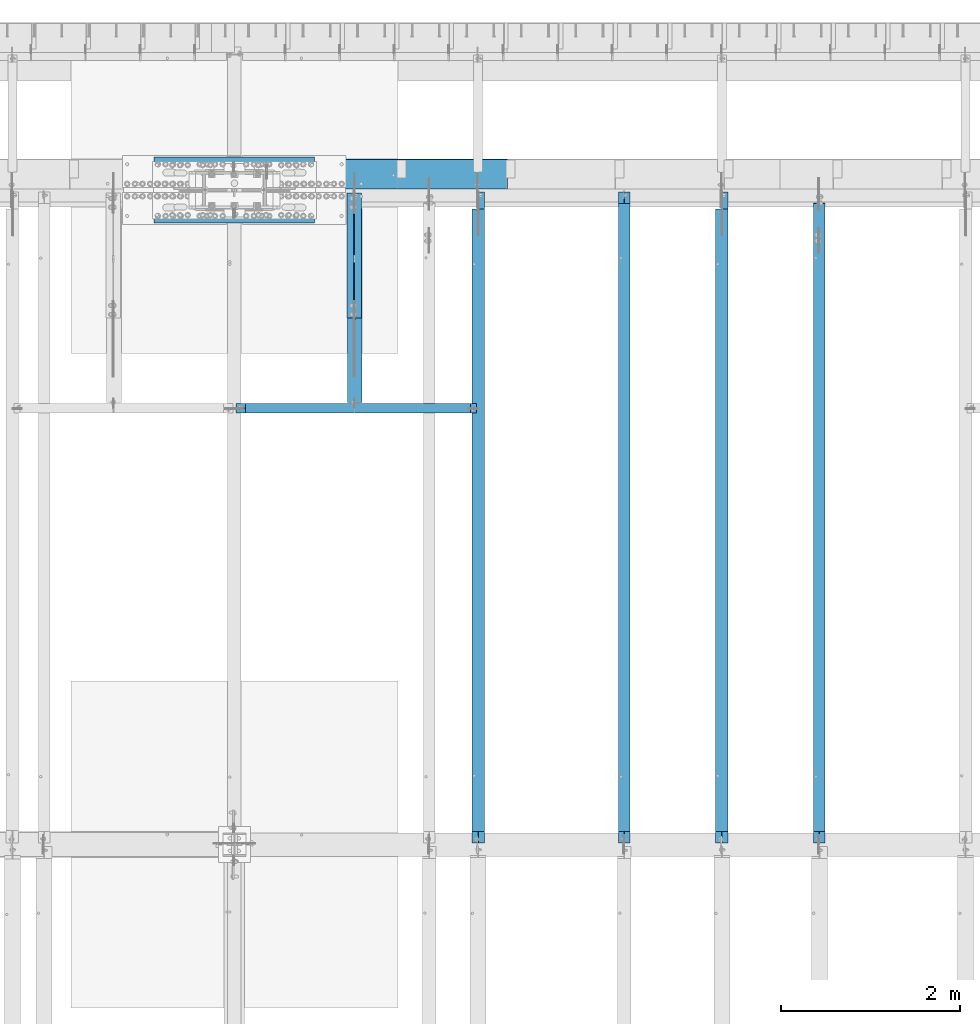
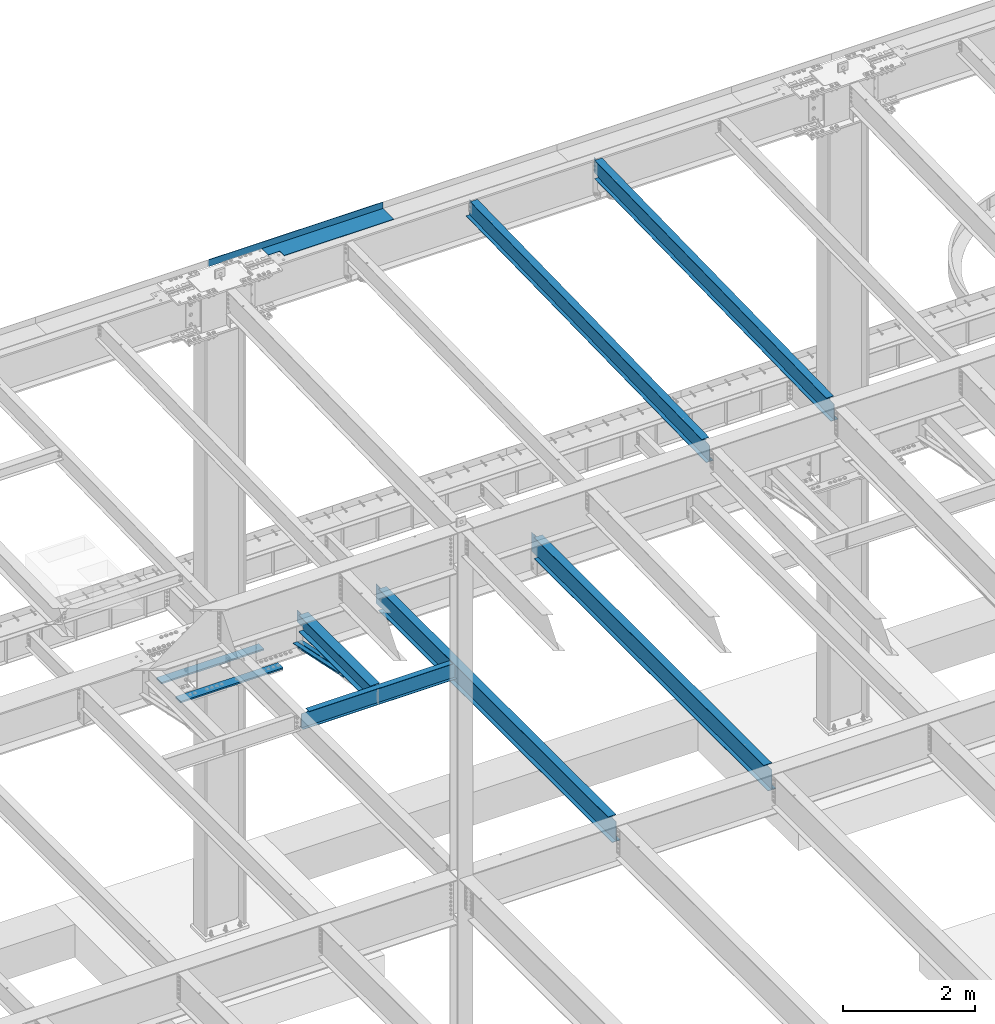
# One storey, part 1129 of 1763: 11 beams, 9 elements without a shape of their own.
"""IFC2X3 building model written with IfcOpenShell, lengths in millimetres."""

from ifc_helpers import new_model, si_unit, frame, origin_with_axes, place, context, subcontext, project, spatial, faceted_brep, material, type_object, element, aggregate, save


model = new_model("IFC2X3")

# Units and contexts
model_context = context("Model", 3, precision=1e-05, world=origin_with_axes())
body_context = subcontext(model_context, "Body", "Model", "MODEL_VIEW")
ifc_project = project(units=[si_unit("LENGTHUNIT", "METRE", prefix="MILLI"), si_unit("AREAUNIT", "SQUARE_METRE"), si_unit("VOLUMEUNIT", "CUBIC_METRE"), si_unit("MASSUNIT", "GRAM", prefix="KILO"), si_unit("TIMEUNIT", "SECOND"), si_unit("PLANEANGLEUNIT", "RADIAN"), si_unit("SOLIDANGLEUNIT", "STERADIAN"), si_unit("THERMODYNAMICTEMPERATUREUNIT", "DEGREE_CELSIUS"), si_unit("LUMINOUSINTENSITYUNIT", "LUMEN")], contexts=[model_context])

# Site, building, storey
site_placement = place(None, origin_with_axes())
site = spatial("IfcSite", under=ifc_project, at=site_placement, CompositionType="ELEMENT")
building_placement = place(site_placement, origin_with_axes())
building = spatial("IfcBuilding", under=site, at=building_placement, Name="Undefined", CompositionType="ELEMENT")
storey_placement = place(building_placement, origin_with_axes())
storey = spatial("IfcBuildingStorey", under=building, at=storey_placement, Name="Undefined", CompositionType="ELEMENT", Elevation=0.0)

# Assembly, beam
assembly_1_placement = place(storey_placement, origin_with_axes())
assembly_1 = element("IfcElementAssembly", 1, at=assembly_1_placement, inside=storey, Name="BEAM", AssemblyPlace="NOTDEFINED", PredefinedType="RIGID_FRAME")
ifc_material_1 = material(Name="STEEL/A992")
beam_type_1 = type_object("IfcBeamType", Name="W16X26", PredefinedType="NOTDEFINED")
beam_1_placement = place(assembly_1_placement, frame((-67042.7372736984, 44805.6, 4994.275), z_axis=(0.0, 0.0, 1.0), x_axis=(0.0, 1.0, 0.0)))
beam_1 = element("IfcBeam", 2, at=beam_1_placement, type_object=beam_type_1, material=ifc_material_1, Name="BEAM", ObjectType="W16X26", context=body_context, shape_type="Brep", body=[
    faceted_brep([(7104.06248869727, 3.17500000000291, -190.5), (7104.06248869734, 3.17487653380522, -200.025), (7104.06247902929, 69.8499999999985, -200.025), (7104.06247902929, 69.8499999999985, -190.5), (7294.5625, 3.17500000000291, -190.5), (7294.5625, 3.17490415680368, -200.025), (146.04999924302, 3.17499999999927, 190.5), (146.04999924302, 69.8499999999985, 190.5), (7104.0625, 69.8499999999985, 190.5), (7104.0625, 3.17500000000291, 190.5), (146.04999943226, -69.8499999999985, 200.025), (146.04999943226, 69.8499999999985, 200.025), (146.04999943226, 3.17500000000291, 180.715001487731), (146.04999943226, -3.17500000000291, 180.715001487731), (146.04999924302, -3.17499999999927, 190.5), (146.04999924302, -69.8499999999985, 190.5), (145.083269509669, 3.17500000000291, 175.854921969685), (145.083269509669, -3.17500000000291, 175.854921969685), (142.330255609195, 3.17500000000291, 171.734745501532), (142.330255609195, -3.17500000000291, 171.734745501532), (138.210079141041, 3.17500000000291, 168.981731601053), (138.210079141041, -3.17500000000291, 168.981731601053), (133.349999622995, 3.17500000000291, 168.015001678466), (133.349999622995, -3.17500000000291, 168.015001678466), (19.0499999999956, 3.17500000000291, 168.015001678466), (19.0499999999956, -3.17500000000291, 168.015001678466), (19.0499999999956, 3.17499999999927, -190.5), (19.0499999999956, 69.8499999999985, -190.5), (19.0499999999956, 69.8499999999985, -200.025), (19.0499999999956, -69.8499999999985, -200.025), (19.0499999999956, -69.8499999999985, -190.5), (19.0499999999956, -3.17499999999927, -190.5), (7294.5625, -69.8499999999985, -200.025), (7294.5625, -69.8499999999985, -190.5), (7294.5625, -3.17500000000291, -190.5), (7111.90242029122, -3.17500000000291, 156.541729922587), (7107.78224382307, -3.17500000000291, 159.294743823066), (7105.02922992258, -3.17500000000291, 163.414920291219), (7104.0625, -3.17500000000291, 168.274999809265), (7104.0625, -3.17500000000291, 190.5), (7294.5625, -3.17500000000291, 155.575), (7116.76249980927, -3.17500000000291, 155.575), (7104.0625, -69.8499999999985, 190.5), (7104.0625, -69.8499999999985, 200.025), (7104.0625, 69.8499999999985, 200.025), (7104.0625, 3.17500000000291, 168.274999809265), (7105.02922992258, 3.17500000000291, 163.414920291219), (7107.78224382307, 3.17500000000291, 159.294743823066), (7111.90242029122, 3.17500000000291, 156.541729922587), (7116.76249980927, 3.17500000000291, 155.575), (7294.5625, 3.17500000000291, 155.575), (7294.5625, 3.17500000000291, -184.976846570121)], [[[0, 1, 2, 3]], [[4, 5, 1, 0]], [[6, 7, 8, 9]], [[10, 11, 7, 6, 12, 13, 14, 15]], [[13, 12, 16, 17]], [[17, 16, 18, 19]], [[19, 18, 20, 21]], [[21, 20, 22, 23]], [[23, 22, 24, 25]], [[26, 27, 28, 29, 30, 31, 25, 24]], [[30, 29, 32, 33]], [[31, 30, 33, 34]], [[35, 36, 37, 38, 39, 14, 13, 17, 19, 21, 23, 25, 31, 34, 40, 41]], [[15, 14, 39, 42]], [[10, 15, 42, 43]], [[11, 10, 43, 44]], [[7, 11, 44, 8]], [[43, 42, 39, 38, 45, 9, 8, 44]], [[37, 46, 45, 38]], [[36, 47, 46, 37]], [[35, 48, 47, 36]], [[41, 49, 48, 35]], [[40, 50, 49, 41]], [[51, 4, 0, 26, 24, 22, 20, 18, 16, 12, 6, 9, 45, 46, 47, 48, 49, 50]], [[27, 26, 0, 3]], [[28, 27, 3, 2]], [[32, 29, 28, 2, 1, 5]], [[51, 50, 40, 34, 33, 32, 5, 4]]]),
])
aggregate(assembly_1, [beam_1])

assembly_2_placement = place(storey_placement, origin_with_axes())
assembly_2 = element("IfcElementAssembly", 3, at=assembly_2_placement, inside=storey, Name="BEAM", AssemblyPlace="NOTDEFINED", PredefinedType="RIGID_FRAME")
beam_2_placement = place(assembly_2_placement, frame((-69766.8872736983, 44805.6, 4994.275), z_axis=(0.0, 0.0, 1.0), x_axis=(0.0, 1.0, 0.0)))
beam_2 = element("IfcBeam", 4, at=beam_2_placement, type_object=beam_type_1, material=ifc_material_1, Name="BEAM", ObjectType="W16X26", context=body_context, shape_type="Brep", body=[
    faceted_brep([(7104.06248869727, 3.17500000000291, -190.5), (7104.06248869734, 3.17487653380522, -200.025), (7104.06247902929, 69.8499999999985, -200.025), (7104.06247902929, 69.8499999999985, -190.5), (7294.5625, 3.17500000000291, -190.5), (7294.5625, 3.17490415680368, -200.025), (146.04999924302, 3.17499999999927, 190.5), (146.04999924302, 69.8499999999985, 190.5), (7104.0625, 69.8499999999985, 190.5), (7104.0625, 3.17500000000291, 190.5), (146.04999943226, -69.8499999999985, 200.025), (146.04999943226, 69.8499999999985, 200.025), (146.04999943226, 3.17500000000291, 180.715001487731), (146.04999943226, -3.17500000000291, 180.715001487731), (146.04999924302, -3.17499999999927, 190.5), (146.04999924302, -69.8499999999985, 190.5), (145.083269509669, 3.17500000000291, 175.854921969685), (145.083269509669, -3.17500000000291, 175.854921969685), (142.330255609195, 3.17500000000291, 171.734745501532), (142.330255609195, -3.17500000000291, 171.734745501532), (138.210079141041, 3.17500000000291, 168.981731601053), (138.210079141041, -3.17500000000291, 168.981731601053), (133.349999622995, 3.17500000000291, 168.015001678466), (133.349999622995, -3.17500000000291, 168.015001678466), (19.0499999999956, 3.17500000000291, 168.015001678466), (19.0499999999956, -3.17500000000291, 168.015001678466), (19.0499999999956, 3.17499999999927, -190.5), (19.0499999999956, 69.8499999999985, -190.5), (19.0499999999956, 69.8499999999985, -200.025), (19.0499999999956, -69.8499999999985, -200.025), (19.0499999999956, -69.8499999999985, -190.5), (19.0499999999956, -3.17499999999927, -190.5), (7294.5625, -69.8499999999985, -200.025), (7294.5625, -69.8499999999985, -190.5), (7294.5625, -3.17500000000291, -190.5), (7111.90242029122, -3.17500000000291, 156.541729922587), (7107.78224382307, -3.17500000000291, 159.294743823066), (7105.02922992258, -3.17500000000291, 163.414920291219), (7104.0625, -3.17500000000291, 168.274999809265), (7104.0625, -3.17500000000291, 190.5), (7294.5625, -3.17500000000291, 155.575), (7116.76249980927, -3.17500000000291, 155.575), (7104.0625, -69.8499999999985, 190.5), (7104.0625, -69.8499999999985, 200.025), (7104.0625, 69.8499999999985, 200.025), (7104.0625, 3.17500000000291, 168.274999809265), (7105.02922992258, 3.17500000000291, 163.414920291219), (7107.78224382307, 3.17500000000291, 159.294743823066), (7111.90242029122, 3.17500000000291, 156.541729922587), (7116.76249980927, 3.17500000000291, 155.575), (7294.5625, 3.17500000000291, 155.575), (7294.5625, 3.17500000000291, -184.976846570121)], [[[0, 1, 2, 3]], [[4, 5, 1, 0]], [[6, 7, 8, 9]], [[10, 11, 7, 6, 12, 13, 14, 15]], [[13, 12, 16, 17]], [[17, 16, 18, 19]], [[19, 18, 20, 21]], [[21, 20, 22, 23]], [[23, 22, 24, 25]], [[26, 27, 28, 29, 30, 31, 25, 24]], [[30, 29, 32, 33]], [[31, 30, 33, 34]], [[35, 36, 37, 38, 39, 14, 13, 17, 19, 21, 23, 25, 31, 34, 40, 41]], [[15, 14, 39, 42]], [[10, 15, 42, 43]], [[11, 10, 43, 44]], [[7, 11, 44, 8]], [[43, 42, 39, 38, 45, 9, 8, 44]], [[37, 46, 45, 38]], [[36, 47, 46, 37]], [[35, 48, 47, 36]], [[41, 49, 48, 35]], [[40, 50, 49, 41]], [[51, 4, 0, 26, 24, 22, 20, 18, 16, 12, 6, 9, 45, 46, 47, 48, 49, 50]], [[27, 26, 0, 3]], [[28, 27, 3, 2]], [[32, 29, 28, 2, 1, 5]], [[51, 50, 40, 34, 33, 32, 5, 4]]]),
])
aggregate(assembly_2, [beam_2])

# Assembly, beams
assembly_3_placement = place(storey_placement, origin_with_axes())
assembly_3 = element("IfcElementAssembly", 5, at=assembly_3_placement, inside=storey, Name="COLUMN", AssemblyPlace="NOTDEFINED", PredefinedType="RIGID_FRAME")
ifc_material_2 = material(Name="STEEL/A572-50")
beam_type_2 = type_object("IfcBeamType", PredefinedType="NOTDEFINED")
beam_3_placement = place(assembly_3_placement, frame((-71594.0997736984, 52409.725, 4433.8875), z_axis=(0.0, -1.0, 0.0), x_axis=(-1.0, 0.0, 0.0)))
beam_3 = element("IfcBeam", 6, at=beam_3_placement, type_object=beam_type_2, material=ifc_material_2, Name="PLATE", context=body_context, shape_type="Brep", body=[
    faceted_brep([(0.0, 14.2875000000004, -79.375), (0.0, 14.2875000000004, 79.375), (1793.875, 14.2875000000004, 79.375), (1793.875, 14.2875000000004, -79.375), (0.0, -14.2875000000004, 79.375), (1793.875, -14.2875000000004, 79.375), (0.0, -14.2875000000004, -79.375), (1793.875, -14.2875000000004, -79.375)], [[[0, 1, 2, 3]], [[1, 4, 5, 2]], [[4, 6, 7, 5]], [[6, 0, 3, 7]], [[5, 7, 3, 2]], [[6, 4, 1, 0]]]),
])
beam_4_placement = place(assembly_3_placement, frame((-71594.0997736984, 51831.875, 4433.8875), z_axis=(0.0, -1.0, 0.0), x_axis=(-1.0, 0.0, 0.0)))
beam_4 = element("IfcBeam", 7, at=beam_4_placement, type_object=beam_type_2, material=ifc_material_2, Name="PLATE", context=body_context, shape_type="Brep", body=[
    faceted_brep([(0.0, 14.2875000000004, -79.375), (0.0, 14.2875000000004, 79.375), (1793.875, 14.2875000000004, 79.375), (1793.875, 14.2875000000004, -79.375), (0.0, -14.2875000000004, 79.375), (1793.875, -14.2875000000004, 79.375), (0.0, -14.2875000000004, -79.375), (1793.875, -14.2875000000004, -79.375)], [[[0, 1, 2, 3]], [[1, 4, 5, 2]], [[4, 6, 7, 5]], [[6, 0, 3, 7]], [[5, 7, 3, 2]], [[6, 4, 1, 0]]]),
])
aggregate(assembly_3, [beam_3, beam_4])

# Assembly, beam
assembly_4_placement = place(storey_placement, origin_with_axes())
assembly_4 = element("IfcElementAssembly", 8, at=assembly_4_placement, inside=storey, Name="BEAM", AssemblyPlace="NOTDEFINED", PredefinedType="RIGID_FRAME")
beam_type_3 = type_object("IfcBeamType", Name="W14X22", PredefinedType="NOTDEFINED")
beam_5_placement = place(assembly_4_placement, frame((-65953.0772736983, 44809.2121579121, 11421.5633921212), z_axis=(0.0, -0.0206852279954837, 0.999786037781472), x_axis=(0.0, 0.999786037781472, 0.0206852279954825)))
beam_5 = element("IfcBeam", 9, at=beam_5_placement, type_object=beam_type_3, material=ifc_material_1, Name="BEAM", ObjectType="W14X22", context=body_context, shape_type="Brep", body=[
    faceted_brep([(7162.77359555585, -3.17500000000291, -166.687500001777), (7162.77359555585, -63.5, -166.687500001777), (7162.77359555585, -63.5, -174.625000001772), (7162.77359555585, 63.5, -174.625000001772), (7162.77359555585, 63.5, -166.687500001777), (7162.77359555585, 3.17500000000291, -166.687500001777), (7162.77359555586, 3.17500000000291, -155.574999838074), (7162.77359555586, -3.17500000000291, -155.574999838074), (7163.74032547845, 3.17500000000291, -150.714920320039), (7163.74032547845, -3.17500000000291, -150.714920320039), (7166.49333937895, 3.17500000000291, -146.594743851894), (7166.49333937895, -3.17500000000291, -146.594743851894), (7170.61351584714, 3.17500000000291, -143.841729951426), (7170.61351584714, -3.17500000000291, -143.841729951426), (7175.47359536523, 3.17500000000291, -142.87500002884), (7175.47359536523, -3.17500000000291, -142.87500002884), (7289.55462988591, -3.17500000000291, -142.875000028898), (7289.55462988591, 3.17500000000291, -142.875000028898), (148.791145859177, 3.17500000000291, 166.687499999833), (148.791145859177, 63.5, 166.687499999833), (7169.123595556, 63.5, 166.68749999797), (7169.123595556, 3.17500000000291, 166.68749999797), (11.9924390219312, 3.17500000000291, -166.687499999878), (11.9924390219312, 63.5, -166.687499999878), (11.8282148869548, 63.5, -174.624999999871), (11.8282148869548, -63.5, -174.624999999871), (11.9924390219312, -63.5, -166.687499999878), (11.9924390219312, -3.17500000000291, -166.687499999878), (17.9976630864912, -3.17500000000291, 123.56500167838), (17.9976630864912, 3.17500000000291, 123.56500167838), (136.091146049795, -3.17500000000291, 123.565001678358), (136.091146049795, 3.17500000000291, 123.565001678358), (140.951225567893, -3.17500000000291, 124.531731600942), (140.951225567893, 3.17500000000291, 124.531731600942), (145.071402036083, -3.17500000000291, 127.284745501414), (145.071402036083, 3.17500000000291, 127.284745501414), (147.824415936586, -3.17500000000291, 131.404921969557), (147.824415936586, 3.17500000000291, 131.404921969557), (148.791145859177, -3.17500000000291, 136.265001487593), (148.791145859177, 3.17500000000291, 136.265001487593), (148.79114585917, -63.5, 174.624999999827), (148.79114585917, 63.5, 174.624999999827), (148.791145859177, -3.17500000000291, 166.687499999833), (148.791145859177, -63.5, 166.687499999833), (7169.123595556, -3.17500000000291, 166.68749999797), (7169.123595556, -63.5, 166.68749999797), (7169.123595556, -63.5, 174.624999997965), (7169.123595556, 63.5, 174.624999997965), (7169.123595556, -3.17500000000291, 142.875000542512), (7169.123595556, 3.17500000000291, 142.875000542512), (7170.0903254786, -3.17500000000291, 138.014921024478), (7170.0903254786, 3.17500000000291, 138.014921024478), (7172.8433393791, -3.17500000000291, 133.894744556334), (7172.8433393791, 3.17500000000291, 133.894744556334), (7176.96351584728, -3.17500000000291, 131.14173065586), (7176.96351584728, 3.17500000000291, 131.14173065586), (7181.82359536537, -3.17500000000291, 130.175000733272), (7181.82359536537, 3.17500000000291, 130.175000733272), (7295.20394014482, -3.17500000000291, 130.17500073325), (7295.20394014482, 3.17500000000291, 130.17500073325)], [[[0, 1, 2, 3, 4, 5, 6, 7]], [[7, 6, 8, 9]], [[9, 8, 10, 11]], [[11, 10, 12, 13]], [[13, 12, 14, 15]], [[16, 15, 14, 17]], [[18, 19, 20, 21]], [[22, 23, 24, 25, 26, 27, 28, 29]], [[30, 31, 29, 28]], [[32, 33, 31, 30]], [[34, 35, 33, 32]], [[36, 37, 35, 34]], [[38, 39, 37, 36]], [[40, 41, 19, 18, 39, 38, 42, 43]], [[43, 42, 44, 45]], [[40, 43, 45, 46]], [[41, 40, 46, 47]], [[19, 41, 47, 20]], [[46, 45, 44, 48, 49, 21, 20, 47]], [[50, 51, 49, 48]], [[52, 53, 51, 50]], [[54, 55, 53, 52]], [[56, 57, 55, 54]], [[58, 59, 57, 56]], [[59, 58, 16, 17]], [[12, 10, 8, 6, 5, 22, 29, 31, 33, 35, 37, 39, 18, 21, 49, 51, 53, 55, 57, 59, 17, 14]], [[23, 22, 5, 4]], [[24, 23, 4, 3]], [[25, 24, 3, 2]], [[26, 25, 2, 1]], [[27, 26, 1, 0]], [[58, 56, 54, 52, 50, 48, 44, 42, 38, 36, 34, 32, 30, 28, 27, 0, 7, 9, 11, 13, 15, 16]]]),
])
aggregate(assembly_4, [beam_5])

assembly_5_placement = place(storey_placement, origin_with_axes())
assembly_5 = element("IfcElementAssembly", 10, at=assembly_5_placement, inside=storey, Name="BEAM", AssemblyPlace="NOTDEFINED", PredefinedType="RIGID_FRAME")
beam_6_placement = place(assembly_5_placement, frame((-68132.3972736984, 44809.2121579121, 11421.5633921212), z_axis=(0.0, -0.0206852279954837, 0.999786037781472), x_axis=(0.0, 0.999786037781472, 0.0206852279954825)))
beam_6 = element("IfcBeam", 11, at=beam_6_placement, type_object=beam_type_3, material=ifc_material_1, Name="BEAM", ObjectType="W14X22", context=body_context, shape_type="Brep", body=[
    faceted_brep([(136.091146049795, -3.17500000000291, 123.565001678358), (136.091146049795, 3.17500000000291, 123.565001678358), (17.9976630864912, 3.17500000000291, 123.56500167838), (17.9976630864912, -3.17500000000291, 123.56500167838), (140.951225567893, -3.17500000000291, 124.531731600942), (140.951225567893, 3.17500000000291, 124.531731600942), (145.071402036083, -3.17500000000291, 127.284745501414), (145.071402036083, 3.17500000000291, 127.284745501414), (147.824415936586, -3.17500000000291, 131.404921969557), (147.824415936586, 3.17500000000291, 131.404921969557), (148.791145859177, -3.17500000000291, 136.265001487593), (148.791145859177, 3.17500000000291, 136.265001487593), (148.79114585917, -63.5, 174.624999999827), (148.79114585917, 63.5, 174.624999999827), (148.791145859177, 63.5, 166.687499999833), (148.791145859177, 3.17500000000291, 166.687499999833), (148.791145859177, -3.17500000000291, 166.687499999833), (148.791145859177, -63.5, 166.687499999833), (11.9924390219312, -3.17500000000291, -166.687499999878), (11.9924390219312, -63.5, -166.687499999878), (7289.06195724197, -63.5, -166.687500001812), (7289.06195724197, -3.17500000000291, -166.687500001812), (11.8282148869548, -63.5, -174.624999999871), (7288.89773310699, -63.5, -174.625000001806), (11.8282148869548, 63.5, -174.624999999871), (7288.89773310699, 63.5, -174.625000001806), (11.9924390219312, 63.5, -166.687499999878), (7289.06195724197, 63.5, -166.687500001812), (11.9924390219312, 3.17500000000291, -166.687499999878), (7289.06195724197, 3.17500000000291, -166.687500001812), (7294.93580191941, 3.17500000000291, 117.21499785159), (7294.93580191941, -3.17500000000291, 117.21499785159), (7178.21066392501, 3.17500000000291, 117.214997851612), (7178.21066392501, -3.17500000000291, 117.214997851612), (7173.35058440694, 3.17500000000291, 118.181727774199), (7173.35058440694, -3.17500000000291, 118.181727774199), (7169.23040793875, 3.17500000000291, 120.934741674671), (7169.23040793875, -3.17500000000291, 120.934741674671), (7166.47739403824, 3.17500000000291, 125.054918142816), (7166.47739403824, -3.17500000000291, 125.054918142816), (7165.51066411565, 3.17500000000291, 129.91499766085), (7165.51066411565, -3.17500000000291, 129.91499766085), (7165.51066411565, -63.5, 174.624999997965), (7165.51066411565, -63.5, 166.68749999797), (7165.51066411565, -3.17500000000291, 166.68749999797), (7165.51066411565, 3.17500000000291, 166.68749999797), (7165.51066411565, 63.5, 166.68749999797), (7165.51066411565, 63.5, 174.624999997965)], [[[0, 1, 2, 3]], [[4, 5, 1, 0]], [[6, 7, 5, 4]], [[8, 9, 7, 6]], [[10, 11, 9, 8]], [[12, 13, 14, 15, 11, 10, 16, 17]], [[18, 19, 20, 21]], [[19, 22, 23, 20]], [[22, 24, 25, 23]], [[24, 26, 27, 25]], [[26, 28, 29, 27]], [[21, 20, 23, 25, 27, 29, 30, 31]], [[31, 30, 32, 33]], [[33, 32, 34, 35]], [[35, 34, 36, 37]], [[37, 36, 38, 39]], [[39, 38, 40, 41]], [[42, 43, 44, 41, 40, 45, 46, 47]], [[43, 42, 12, 17]], [[44, 43, 17, 16]], [[8, 6, 4, 0, 3, 18, 21, 31, 33, 35, 37, 39, 41, 44, 16, 10]], [[28, 26, 24, 22, 19, 18, 3, 2]], [[45, 40, 38, 36, 34, 32, 30, 29, 28, 2, 1, 5, 7, 9, 11, 15]], [[46, 45, 15, 14]], [[47, 46, 14, 13]], [[42, 47, 13, 12]]]),
])
aggregate(assembly_5, [beam_6])

# Assembly, beams
assembly_6_placement = place(storey_placement, origin_with_axes())
assembly_6 = element("IfcElementAssembly", 12, at=assembly_6_placement, inside=storey, Name="ANGLE BRACE", AssemblyPlace="NOTDEFINED", PredefinedType="RIGID_FRAME")
ifc_material_3 = material(Name="STEEL/A36")
beam_type_4 = type_object("IfcBeamType", Name="L4X3X5/16", PredefinedType="NOTDEFINED")
beam_7_placement = place(assembly_6_placement, frame((-71195.6372736984, 50680.4564530846, 4820.75267554856), z_axis=(0.0, -0.2072236520035, -0.978293595016513), x_axis=(0.0, 0.978293600950479, -0.20722362398951)))
beam_7 = element("IfcBeam", 13, at=beam_7_placement, type_object=beam_type_4, material=ifc_material_3, Name="ANGLE BRACE", ObjectType="L4X3X5/16", context=body_context, shape_type="Brep", body=[
    faceted_brep([(1.45519152283669e-10, 38.0999999999985, -50.7999999999993), (1.45519152283669e-10, 38.0999999999985, 50.7999999999993), (1427.42255777739, 38.0999999999985, 50.7999999995518), (1427.42255777754, 38.0999999999985, -50.8000000004868), (-7.27595761418343e-11, 30.1624999999985, 50.8000000000211), (1427.42255777739, 30.1624999999985, 50.7999999995518), (7.27595761418343e-11, 30.1624999999985, -42.8625000000175), (1427.42255777754, 30.1624999999985, -42.8625000004868), (7.27595761418343e-11, -38.0999999999985, -42.8625000000175), (1427.42255777754, -38.0999999999985, -42.8625000004868), (-1.23691279441118e-10, -38.1000000000022, -50.7999999999993), (1427.42255777754, -38.0999999999985, -50.8000000004868)], [[[0, 1, 2, 3]], [[1, 4, 5, 2]], [[4, 6, 7, 5]], [[6, 8, 9, 7]], [[8, 10, 11, 9]], [[10, 0, 3, 11]], [[5, 7, 9, 11, 3, 2]], [[10, 8, 6, 4, 1, 0]]]),
])
beam_8_placement = place(assembly_6_placement, frame((-71109.9122736983, 52076.9355387112, 4524.94833056974), z_axis=(0.0, -0.2072236520035, -0.978293595016513), x_axis=(0.0, -0.978293595016513, 0.207223652003498)))
beam_8 = element("IfcBeam", 14, at=beam_8_placement, type_object=beam_type_4, material=ifc_material_3, Name="ANGLE BRACE", ObjectType="L4X3X5/16", context=body_context, shape_type="Brep", body=[
    faceted_brep([(1.45519152283669e-10, 38.0999999999985, -50.7999999999993), (1.45519152283669e-10, 38.0999999999985, 50.7999999999993), (1427.46422513096, 38.0999999999985, 50.7999999991189), (1427.46422513096, 38.0999999999985, -50.8000000008396), (-7.27595761418343e-11, 30.1624999999985, 50.8000000000211), (1427.46422513096, 30.1624999999985, 50.7999999991189), (7.27595761418343e-11, 30.1624999999985, -42.8625000000175), (1427.46422513096, 30.1624999999985, -42.8625000008433), (7.27595761418343e-11, -38.0999999999985, -42.8625000000175), (1427.46422513096, -38.0999999999985, -42.8625000008433), (-1.23691279441118e-10, -38.1000000000022, -50.7999999999993), (1427.46422513096, -38.0999999999985, -50.8000000008396)], [[[0, 1, 2, 3]], [[1, 4, 5, 2]], [[4, 6, 7, 5]], [[6, 8, 9, 7]], [[8, 10, 11, 9]], [[10, 0, 3, 11]], [[5, 7, 9, 11, 3, 2]], [[10, 8, 6, 4, 1, 0]]]),
])
aggregate(assembly_6, [beam_7, beam_8])

# Assembly, beam
assembly_7_placement = place(storey_placement, origin_with_axes())
assembly_7 = element("IfcElementAssembly", 15, at=assembly_7_placement, inside=storey, Name="BEAM", AssemblyPlace="NOTDEFINED", PredefinedType="RIGID_FRAME")
beam_type_5 = type_object("IfcBeamType", PredefinedType="NOTDEFINED")
beam_9_placement = place(assembly_7_placement, frame((-70963.8617736983, 52133.5000002128, 11752.2624917654), z_axis=(-1.0, 0.0, 0.0), x_axis=(0.0, 1.0, 0.0)))
beam_9 = element("IfcBeam", 16, at=beam_9_placement, type_object=beam_type_5, material=ifc_material_3, Name="BENT_PLATE", context=body_context, shape_type="Brep", body=[
    faceted_brep([(133.349999999999, -4.76250000000073, 395.288085937507), (133.349999999999, 4.76250000000073, 395.288085937507), (0.0, 4.76250000000073, 395.288085937507), (0.0, -4.76250000000073, 395.288085937507), (133.349999999999, -4.76250000000073, 598.487976074226), (133.349999999999, 4.76250000000073, 598.487976074226), (327.024987792975, -4.76250000000073, 598.487976074226), (327.02498779296, 4.76250000000073, 598.487976074226), (327.024987792967, -4.76250000000073, 1524.00000000001), (327.024987792967, 4.76250000000073, 1524.0), (327.024987792975, -4.76250000000073, -1524.0), (0.0, -4.76249999999982, -1524.0), (0.0, 4.76249999999982, -1524.0), (336.549987792969, 4.76250000000073, -1524.0), (336.549987792969, -122.237499999999, -1524.0), (327.024987792975, -122.237499999999, -1524.0), (336.549987792969, 4.76250000000073, 1524.0), (336.549987792969, -122.237499999999, 1524.0), (327.024987792975, -122.237499999999, 1524.0), (327.024987792975, -99.5375007629373, 1524.0)], [[[0, 1, 2, 3]], [[4, 5, 1, 0]], [[6, 7, 5, 4]], [[8, 9, 7, 6]], [[10, 11, 12, 13, 14, 15]], [[13, 16, 17, 14]], [[18, 15, 14, 17]], [[19, 8, 6, 10, 15, 18]], [[0, 3, 11, 10, 6, 4]], [[12, 11, 3, 2]], [[16, 13, 12, 2, 1, 5, 7, 9]], [[19, 18, 17, 16, 9, 8]]]),
])
aggregate(assembly_7, [beam_9])

assembly_8_placement = place(storey_placement, origin_with_axes())
assembly_8 = element("IfcElementAssembly", 17, at=assembly_8_placement, inside=storey, Name="BEAM", AssemblyPlace="NOTDEFINED", PredefinedType="RIGID_FRAME")
beam_type_6 = type_object("IfcBeamType", Name="W12X26", PredefinedType="NOTDEFINED")
beam_10_placement = place(assembly_8_placement, frame((-71144.8372736984, 49682.4, 5038.725), z_axis=(0.0, 0.0, 1.0), x_axis=(0.0, 1.0, 0.0)))
beam_10 = element("IfcBeam", 18, at=beam_10_placement, type_object=beam_type_6, material=ifc_material_1, Name="BEAM", ObjectType="W12X26", context=body_context, shape_type="Brep", body=[
    faceted_brep([(2233.6125, -3.17500000000291, -146.05), (2233.6125, -82.5500000000029, -146.05), (2233.6125, -82.5500000000029, -155.575), (2233.6125, 82.5500000000029, -155.575), (2233.6125, 82.5500000000029, -146.05), (2233.6125, 3.17500000000291, -146.05), (2233.6125, 3.17500000000291, -123.824999809265), (2233.6125, -3.17500000000291, -123.824999809265), (2234.57922992259, 3.17500000000291, -118.96492029122), (2234.57922992259, -3.17500000000291, -118.96492029122), (2237.33224382307, 3.17500000000291, -114.844743823066), (2237.33224382307, -3.17500000000291, -114.844743823066), (2241.45242029122, 3.17500000000291, -112.091729922588), (2241.45242029122, -3.17500000000291, -112.091729922588), (2246.31249980927, 3.17500000000291, -111.125), (2246.31249980927, -3.17500000000291, -111.125), (2417.7625, -3.17500000000291, -111.125), (2417.7625, 3.17500000000291, -111.125), (65.8812499999913, 3.17500000000291, 146.05), (65.8812499999913, 82.5500000000029, 146.05), (2233.6125, 82.5500000000029, 146.05), (2233.6125, 3.17500000000291, 146.05), (65.8812499999913, -3.17500000000291, -123.824999809265), (65.8812499999913, 3.17500000000291, -123.824999809265), (65.8812499999913, 3.17500000000291, -146.05), (65.8812499999913, 82.5500000000029, -146.05), (65.8812499999913, 82.5500000000029, -155.575), (65.8812499999913, -82.5500000000029, -155.575), (65.8812499999913, -82.5500000000029, -146.05), (65.8812499999913, -3.17500000000291, -146.05), (64.9145200774001, -3.17500000000291, -118.96492029122), (64.9145200774001, 3.17500000000291, -118.96492029122), (62.1615061769262, -3.17500000000291, -114.844743823066), (62.1615061769262, 3.17500000000291, -114.844743823066), (58.0413297087725, -3.17500000000291, -112.091729922588), (58.0413297087725, 3.17500000000291, -112.091729922588), (53.1812501907261, -3.17500000000291, -111.125), (53.1812501907261, 3.17500000000291, -111.125), (15.0812499999956, -3.17500000000291, -111.125), (15.0812499999956, 3.17500000000291, -111.125), (15.0812499999956, -3.17500000000291, 117.475), (15.0812499999956, 3.17500000000291, 117.475), (53.1812501907261, -3.17500000000291, 117.475), (53.1812501907261, 3.17500000000291, 117.475), (58.0413297087725, -3.17500000000291, 118.441729922588), (58.0413297087725, 3.17500000000291, 118.441729922588), (62.1615061769262, -3.17500000000291, 121.194743823066), (62.1615061769262, 3.17500000000291, 121.194743823066), (64.9145200774001, -3.17500000000291, 125.31492029122), (64.9145200774001, 3.17500000000291, 125.31492029122), (65.8812499999913, -3.17500000000291, 130.174999809266), (65.8812499999913, 3.17500000000291, 130.174999809266), (65.8812499999913, -82.5500000000029, 155.575), (65.8812499999913, 82.5500000000029, 155.575), (65.8812499999913, -3.17500000000291, 146.05), (65.8812499999913, -82.5500000000029, 146.05), (2233.6125, -3.17500000000291, 146.05), (2233.6125, -82.5500000000029, 146.05), (2233.6125, -82.5500000000029, 155.575), (2233.6125, 82.5500000000029, 155.575), (2233.6125, -3.17500000000291, 123.824999809265), (2233.6125, 3.17500000000291, 123.824999809265), (2234.57922992259, -3.17500000000291, 118.96492029122), (2234.57922992259, 3.17500000000291, 118.96492029122), (2237.33224382307, -3.17500000000291, 114.844743823066), (2237.33224382307, 3.17500000000291, 114.844743823066), (2241.45242029122, -3.17500000000291, 112.091729922588), (2241.45242029122, 3.17500000000291, 112.091729922588), (2246.31249980927, -3.17500000000291, 111.125), (2246.31249980927, 3.17500000000291, 111.125), (2417.7625, -3.17500000000291, 111.125), (2417.7625, 3.17500000000291, 111.125)], [[[0, 1, 2, 3, 4, 5, 6, 7]], [[7, 6, 8, 9]], [[9, 8, 10, 11]], [[11, 10, 12, 13]], [[13, 12, 14, 15]], [[16, 15, 14, 17]], [[18, 19, 20, 21]], [[22, 23, 24, 25, 26, 27, 28, 29]], [[30, 31, 23, 22]], [[32, 33, 31, 30]], [[34, 35, 33, 32]], [[36, 37, 35, 34]], [[38, 39, 37, 36]], [[40, 41, 39, 38]], [[42, 43, 41, 40]], [[44, 45, 43, 42]], [[46, 47, 45, 44]], [[48, 49, 47, 46]], [[50, 51, 49, 48]], [[52, 53, 19, 18, 51, 50, 54, 55]], [[55, 54, 56, 57]], [[52, 55, 57, 58]], [[53, 52, 58, 59]], [[19, 53, 59, 20]], [[58, 57, 56, 60, 61, 21, 20, 59]], [[62, 63, 61, 60]], [[64, 65, 63, 62]], [[66, 67, 65, 64]], [[68, 69, 67, 66]], [[70, 71, 69, 68]], [[71, 70, 16, 17]], [[12, 10, 8, 6, 5, 24, 23, 31, 33, 35, 37, 39, 41, 43, 45, 47, 49, 51, 18, 21, 61, 63, 65, 67, 69, 71, 17, 14]], [[25, 24, 5, 4]], [[26, 25, 4, 3]], [[27, 26, 3, 2]], [[28, 27, 2, 1]], [[29, 28, 1, 0]], [[70, 68, 66, 64, 62, 60, 56, 54, 50, 48, 46, 44, 42, 40, 38, 36, 34, 32, 30, 22, 29, 0, 7, 9, 11, 13, 15, 16]]]),
])
aggregate(assembly_8, [beam_10])

assembly_9_placement = place(storey_placement, origin_with_axes())
assembly_9 = element("IfcElementAssembly", 19, at=assembly_9_placement, inside=storey, Name="BEAM", AssemblyPlace="NOTDEFINED", PredefinedType="RIGID_FRAME")
beam_type_7 = type_object("IfcBeamType", Name="W12X14", PredefinedType="NOTDEFINED")
beam_11_placement = place(assembly_9_placement, frame((-72491.0372736984, 49682.4, 5043.4875), z_axis=(0.0, 0.0, 1.0), x_axis=(1.0, 0.0, 0.0)))
beam_11 = element("IfcBeam", 20, at=beam_11_placement, type_object=beam_type_7, material=ifc_material_1, Name="BEAM", ObjectType="W12X14", context=body_context, shape_type="Brep", body=[
    faceted_brep([(111.918750190736, -2.38124999999854, 118.802501678467), (111.918750190736, 2.38124999999854, 118.802501678467), (16.6687499999971, 2.38124999999854, 118.802501678467), (16.6687499999971, -2.38124999999854, 118.802501678467), (116.778829708783, -2.38124999999854, 119.769231601054), (116.778829708783, 2.38124999999854, 119.769231601054), (120.899006176936, -2.38124999999854, 122.522245501533), (120.899006176936, 2.38124999999854, 122.522245501533), (123.65202007741, -2.38124999999854, 126.642421969686), (123.65202007741, 2.38124999999854, 126.642421969686), (124.618750000001, -2.38124999999854, 131.502501487732), (124.618750000001, 2.38124999999854, 131.502501487732), (124.618750000001, -50.8000000000029, 150.8125), (124.618750000001, 50.8000000000029, 150.8125), (124.618750000001, 50.8000000000029, 144.4625), (124.618750000001, 2.38124999999854, 144.4625), (124.618750000001, -2.38124999999854, 144.4625), (124.618750000001, -50.8000000000029, 144.4625), (16.6687499999971, -2.38124999999854, -144.4625), (16.6687499999898, -50.7999999999993, -144.4625), (2708.27500000001, -50.8000000000029, -144.4625), (2708.27500000001, -2.38124999999854, -144.4625), (16.6687499999971, -50.8000000000029, -150.8125), (2708.27500000001, -50.8000000000029, -150.8125), (16.6687499999971, 50.8000000000029, -150.8125), (2708.27500000001, 50.8000000000029, -150.8125), (16.6687499999898, 50.7999999999993, -144.4625), (2708.27500000001, 50.8000000000029, -144.4625), (16.6687499999971, 2.38124999999854, -144.4625), (2708.27500000001, 2.38124999999854, -144.4625), (2708.27500000001, 2.38124999999854, 125.152501678466), (2708.27500000001, -2.38124999999854, 125.152501678466), (2651.12499980927, 2.38124999999854, 125.152501678466), (2651.12499980927, -2.38124999999854, 125.152501678466), (2646.26492029123, 2.38124999999854, 126.119231601054), (2646.26492029123, -2.38124999999854, 126.119231601054), (2642.14474382307, 2.38124999999854, 128.872245501532), (2642.14474382307, -2.38124999999854, 128.872245501532), (2639.39172992259, 2.38124999999854, 132.992421969686), (2639.39172992259, -2.38124999999854, 132.992421969686), (2638.425, 2.38124999999854, 137.852501487731), (2638.425, -2.38124999999854, 137.852501487731), (2638.425, -50.8000000000029, 150.8125), (2638.425, -50.8000000000029, 144.4625), (2638.425, -2.38124999999854, 144.4625), (2638.425, 2.38124999999854, 144.4625), (2638.425, 50.8000000000029, 144.4625), (2638.425, 50.8000000000029, 150.8125)], [[[0, 1, 2, 3]], [[4, 5, 1, 0]], [[6, 7, 5, 4]], [[8, 9, 7, 6]], [[10, 11, 9, 8]], [[12, 13, 14, 15, 11, 10, 16, 17]], [[18, 19, 20, 21]], [[19, 22, 23, 20]], [[22, 24, 25, 23]], [[24, 26, 27, 25]], [[26, 28, 29, 27]], [[21, 20, 23, 25, 27, 29, 30, 31]], [[31, 30, 32, 33]], [[33, 32, 34, 35]], [[35, 34, 36, 37]], [[37, 36, 38, 39]], [[39, 38, 40, 41]], [[42, 43, 44, 41, 40, 45, 46, 47]], [[43, 42, 12, 17]], [[44, 43, 17, 16]], [[8, 6, 4, 0, 3, 18, 21, 31, 33, 35, 37, 39, 41, 44, 16, 10]], [[28, 26, 24, 22, 19, 18, 3, 2]], [[45, 40, 38, 36, 34, 32, 30, 29, 28, 2, 1, 5, 7, 9, 11, 15]], [[46, 45, 15, 14]], [[47, 46, 14, 13]], [[42, 47, 13, 12]]]),
])
aggregate(assembly_9, [beam_11])

save(model, "model.ifc")
